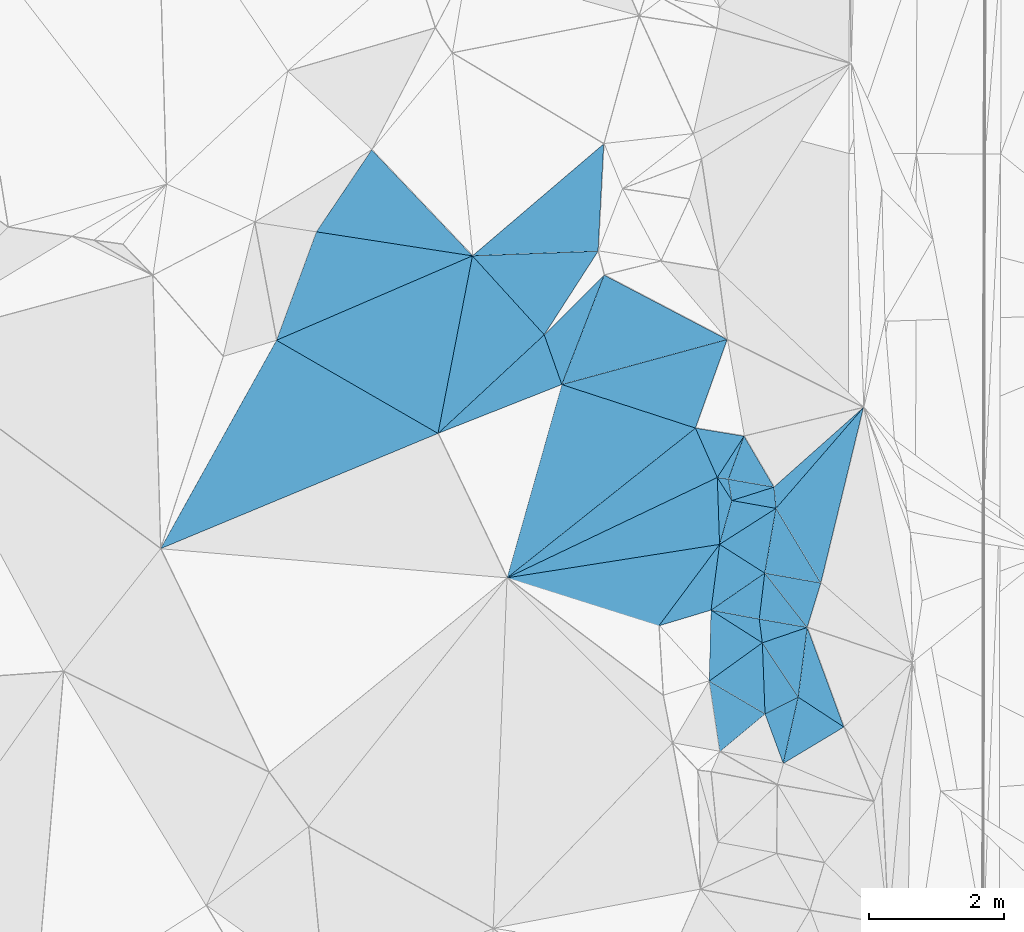
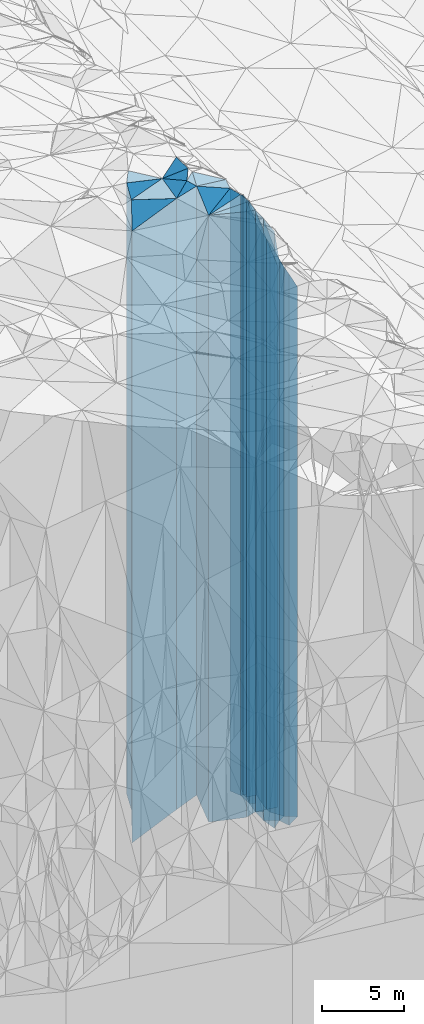
# One storey, part 249 of 275: 42 plates.
"""IFC2X3 building model written with IfcOpenShell, lengths in millimetres."""

from ifc_helpers import new_model, si_unit, frame, origin_with_axes, place, context, subcontext, project, spatial, faceted_brep, material, type_object, element, save


model = new_model("IFC2X3")

# Units and contexts
model_context = context("Model", 3, precision=1e-05, world=origin_with_axes())
body_context = subcontext(model_context, "Body", "Model", "MODEL_VIEW")
ifc_project = project(units=[si_unit("LENGTHUNIT", "METRE", prefix="MILLI"), si_unit("AREAUNIT", "SQUARE_METRE"), si_unit("VOLUMEUNIT", "CUBIC_METRE"), si_unit("MASSUNIT", "GRAM", prefix="KILO"), si_unit("TIMEUNIT", "SECOND"), si_unit("PLANEANGLEUNIT", "RADIAN"), si_unit("SOLIDANGLEUNIT", "STERADIAN"), si_unit("THERMODYNAMICTEMPERATUREUNIT", "DEGREE_CELSIUS"), si_unit("LUMINOUSINTENSITYUNIT", "LUMEN")], contexts=[model_context])

# Site, building, storey
site_placement = place(None, origin_with_axes())
site = spatial("IfcSite", under=ifc_project, at=site_placement, CompositionType="ELEMENT")
building_placement = place(site_placement, origin_with_axes())
building = spatial("IfcBuilding", under=site, at=building_placement, Name="Undefined", CompositionType="ELEMENT")
storey_placement = place(building_placement, origin_with_axes())
storey = spatial("IfcBuildingStorey", under=building, at=storey_placement, Name="Undefined", CompositionType="ELEMENT", Elevation=0.0)

# Plates
ifc_material = material()
plate_type_1 = type_object("IfcPlateType", PredefinedType="NOTDEFINED")
plate_1_placement = place(storey_placement, frame((-100152.82634146, 92751.0020205574, 28714.0), z_axis=(0.58413574837541, -0.811655978521627, 0.0), x_axis=(-0.811655978521627, -0.584135748375411, 0.0)))
element("IfcPlate", 1, at=plate_1_placement, inside=storey, type_object=plate_type_1, material=ifc_material, Name="00", context=body_context, shape_type="Brep", body=[
    faceted_brep([(0.0, -21496.0, 1.45519152283669e-11), (583.524658203136, -20886.0, 878.634704589844), (583.524658203136, 20886.0, 878.634704589844), (1.09139364212751e-11, 20886.0, 0.0), (970.82440185548, -23986.0, -7.39237293601036e-09), (970.82440185548, 20886.0, -7.39237293601036e-09)], [[[0, 1, 2, 3]], [[1, 4, 5, 2]], [[4, 0, 3, 5]], [[5, 3, 2]], [[4, 1, 0]]]),
])
plate_type_2 = type_object("IfcPlateType", PredefinedType="NOTDEFINED")
plate_2_placement = place(storey_placement, frame((-99622.3164634712, 91946.8507478749, 28294.0), z_axis=(0.453608377104646, -0.891201122205583, 0.0), x_axis=(-0.891201122205591, -0.453608377104629, 0.0)))
element("IfcPlate", 2, at=plate_2_placement, inside=storey, type_object=plate_type_2, material=ifc_material, Name="00", context=body_context, shape_type="Brep", body=[
    faceted_brep([(2.18278728425503e-11, -20466.0, 0.0), (643.225646972678, -20636.0, 776.119018554688), (643.225646972678, 20466.0, 776.119018554688), (2.18278728425503e-11, 20466.0, 0.0), (550.817565917969, -21306.0, 4.33647073805332e-09), (550.817565917969, 20466.0, 4.33647073805332e-09)], [[[0, 1, 2, 3]], [[1, 4, 5, 2]], [[4, 0, 3, 5]], [[5, 3, 2]], [[4, 1, 0]]]),
])
plate_type_3 = type_object("IfcPlateType", PredefinedType="NOTDEFINED")
plate_3_placement = place(storey_placement, frame((-99488.353856279, 92979.2043790858, 27584.0), z_axis=(0.991685476762289, -0.128685333969147, 0.0), x_axis=(-0.12868533396916, -0.991685476762288, 0.0)))
element("IfcPlate", 3, at=plate_3_placement, inside=storey, type_object=plate_type_3, material=ifc_material, Name="00", context=body_context, shape_type="Brep", body=[
    faceted_brep([(-1.45519152283669e-11, -20596.0, -1.45519152283669e-11), (1394.12805175781, -19756.0, 728.908142089844), (1394.12805175781, 19756.0, 728.908142089844), (-1.45519152283669e-11, 19756.0, -1.45519152283669e-11), (1041.00915527341, -21176.0, -5.67524693906307e-09), (1041.00915527341, 19756.0, -5.67524693906307e-09)], [[[0, 1, 2, 3]], [[1, 4, 5, 2]], [[4, 0, 3, 5]], [[5, 3, 2]], [[4, 1, 0]]]),
])
plate_type_4 = type_object("IfcPlateType", PredefinedType="NOTDEFINED")
plate_4_placement = place(storey_placement, frame((-100113.205703667, 91696.9952819352, 28294.0), z_axis=(-0.453608377104638, 0.891201122205586, 0.0), x_axis=(0.891201122205586, 0.453608377104638, 0.0)))
element("IfcPlate", 4, at=plate_4_placement, inside=storey, type_object=plate_type_4, material=ifc_material, Name="00", context=body_context, shape_type="Brep", body=[
    faceted_brep([(1.45519152283669e-11, -21306.0, 3.63797880709171e-12), (442.796325683594, -21916.0, 957.304260253892), (442.796325683594, 20466.0, 957.304260253892), (2.18278728425503e-11, 20466.0, 0.0), (550.817565917961, -20466.0, 4.33647073805332e-09), (550.817565917969, 20466.0, 4.33647073805332e-09)], [[[0, 1, 2, 3]], [[1, 4, 5, 2]], [[4, 0, 3, 5]], [[5, 3, 2]], [[4, 1, 0]]]),
])
plate_type_5 = type_object("IfcPlateType", PredefinedType="NOTDEFINED")
plate_5_placement = place(storey_placement, frame((-99843.5058046451, 90963.4000498981, 27584.0), z_axis=(-0.514713642050979, 0.85736215608494, 0.0), x_axis=(0.857362156084938, 0.514713642050983, 0.0)))
element("IfcPlate", 5, at=plate_5_placement, inside=storey, type_object=plate_type_5, material=ifc_material, Name="00", context=body_context, shape_type="Brep", body=[
    faceted_brep([(-7.27595761418343e-12, -21346.0, -1.45519152283669e-11), (695.834838867173, -21176.0, 729.324218750015), (695.834838867173, 19756.0, 729.324218750015), (-1.45519152283669e-11, 19756.0, -1.45519152283669e-11), (1048.09350585937, -19756.0, -1.01863406598568e-08), (1048.09350585937, 19756.0, -1.01863406598568e-08)], [[[0, 1, 2, 3]], [[1, 4, 5, 2]], [[4, 0, 3, 5]], [[5, 3, 2]], [[4, 1, 0]]]),
])
plate_type_6 = type_object("IfcPlateType", PredefinedType="NOTDEFINED")
plate_6_placement = place(storey_placement, frame((-100786.670575956, 94209.234336204, 30264.0), z_axis=(0.155487003987169, -0.98783793791851, 0.0), x_axis=(-0.98783793791851, -0.155487003987171, 0.0)))
element("IfcPlate", 6, at=plate_6_placement, inside=storey, type_object=plate_type_6, material=ifc_material, Name="00", context=body_context, shape_type="Brep", body=[
    faceted_brep([(1.45519152283669e-11, -22436.0, 0.0), (1075.52282714842, -22716.0, 1052.1173095703), (1075.52282714842, 22436.0, 1052.1173095703), (1.45519152283669e-11, 22436.0, 0.0), (3187.28735351563, -22796.0, 1.68220140039921e-08), (3187.28735351563, 22436.0, 1.68220140039921e-08)], [[[0, 1, 2, 3]], [[1, 4, 5, 2]], [[4, 0, 3, 5]], [[5, 3, 2]], [[4, 1, 0]]]),
])
plate_type_7 = type_object("IfcPlateType", PredefinedType="NOTDEFINED")
plate_7_placement = place(storey_placement, frame((-100784.40104888, 91137.8022843352, 28714.0), z_axis=(-0.640092212727741, 0.768298092673218, 0.0), x_axis=(0.768298092673218, 0.640092212727741, 0.0)))
element("IfcPlate", 7, at=plate_7_placement, inside=storey, type_object=plate_type_7, material=ifc_material, Name="00", context=body_context, shape_type="Brep", body=[
    faceted_brep([(-3.63797880709171e-12, -23616.0, 2.91038304567337e-11), (549.442260742177, -23986.0, 903.832519531279), (549.442260742177, 20886.0, 903.832519531279), (1.09139364212751e-11, 20886.0, 0.0), (873.613159179684, -20886.0, -2.4156179279089e-09), (873.613159179684, 20886.0, -2.4156179279089e-09)], [[[0, 1, 2, 3]], [[1, 4, 5, 2]], [[4, 0, 3, 5]], [[5, 3, 2]], [[4, 1, 0]]]),
])
plate_type_8 = type_object("IfcPlateType", PredefinedType="NOTDEFINED")
plate_8_placement = place(storey_placement, frame((-99488.353856279, 92979.2043790858, 28004.0), z_axis=(-0.170841814937067, -0.985298469636997, 0.0), x_axis=(-0.985298469636999, 0.170841814937059, 0.0)))
element("IfcPlate", 8, at=plate_8_placement, inside=storey, type_object=plate_type_8, material=ifc_material, Name="00", context=body_context, shape_type="Brep", body=[
    faceted_brep([(0.0, -20176.0, 0.0), (615.717224121094, -22206.0, 338.367126464844), (615.717224121094, 20176.0, 338.367126464844), (0.0, 20176.0, 0.0), (721.110229492188, -22376.0, -9.60426405072212e-10), (721.110229492188, 20176.0, -9.60426405072212e-10)], [[[0, 1, 2, 3]], [[1, 4, 5, 2]], [[4, 0, 3, 5]], [[5, 3, 2]], [[4, 1, 0]]]),
])
plate_type_9 = type_object("IfcPlateType", PredefinedType="NOTDEFINED")
plate_9_placement = place(storey_placement, frame((-100152.82634146, 92751.0020205574, 29019.0), z_axis=(-0.991527222614213, -0.129899063949456, 0.0), x_axis=(-0.129899063949469, 0.991527222614211, 0.0)))
element("IfcPlate", 9, at=plate_9_placement, inside=storey, type_object=plate_type_9, material=ifc_material, Name="00", context=body_context, shape_type="Brep", body=[
    faceted_brep([(0.0, -21191.0, 0.0), (578.440979003892, -23661.0, 691.307495117188), (578.440979003892, 21191.0, 691.307495117188), (0.0, 21191.0, 0.0), (354.400909423828, -21361.0, -5.82076609134674e-11), (354.400909423828, 21191.0, -5.82076609134674e-11)], [[[0, 1, 2, 3]], [[1, 4, 5, 2]], [[4, 0, 3, 5]], [[5, 3, 2]], [[4, 1, 0]]]),
])
plate_type_10 = type_object("IfcPlateType", PredefinedType="NOTDEFINED")
plate_10_placement = place(storey_placement, frame((-100117.352133444, 93783.5433420383, 28004.0), z_axis=(0.992915865493943, -0.118819544059107, 0.0), x_axis=(-0.118819544059102, -0.992915865493944, 0.0)))
element("IfcPlate", 10, at=plate_10_placement, inside=storey, type_object=plate_type_10, material=ifc_material, Name="00", context=body_context, shape_type="Brep", body=[
    faceted_brep([(-1.45519152283669e-11, -22386.0, 0.0), (723.903625488281, -20176.0, 720.113586425796), (723.903625488281, 20176.0, 720.113586425796), (0.0, 20176.0, 0.0), (686.0029296875, -22376.0, -2.8521753847599e-09), (686.0029296875, 20176.0, -2.8521753847599e-09)], [[[0, 1, 2, 3]], [[1, 4, 5, 2]], [[4, 0, 3, 5]], [[5, 3, 2]], [[4, 1, 0]]]),
])
plate_type_11 = type_object("IfcPlateType", PredefinedType="NOTDEFINED")
plate_11_placement = place(storey_placement, frame((-100117.352133444, 93783.5433420383, 29104.0), z_axis=(0.567587410162593, -0.823313143235866, 0.0), x_axis=(-0.823313143235862, -0.567587410162598, 0.0)))
element("IfcPlate", 11, at=plate_11_placement, inside=storey, type_object=plate_type_11, material=ifc_material, Name="00", context=body_context, shape_type="Brep", body=[
    faceted_brep([(3.63797880709171e-12, -21286.0, 0.0), (453.71701049804, -21276.0, 514.52978515625), (453.71701049804, 21276.0, 514.52978515625), (0.0, 21276.0, 0.0), (966.902282714844, -23576.0, -2.64844857156277e-09), (966.902282714844, 21276.0, -2.64844857156277e-09)], [[[0, 1, 2, 3]], [[1, 4, 5, 2]], [[4, 0, 3, 5]], [[5, 3, 2]], [[4, 1, 0]]]),
])
plate_type_12 = type_object("IfcPlateType", PredefinedType="NOTDEFINED")
plate_12_placement = place(storey_placement, frame((-101685.522203732, 93002.6831556719, 30254.0), z_axis=(-0.287833306916114, 0.957680524720919, 0.0), x_axis=(0.957680524720917, 0.287833306916119, 0.0)))
element("IfcPlate", 12, at=plate_12_placement, inside=storey, type_object=plate_type_12, material=ifc_material, Name="00", context=body_context, shape_type="Brep", body=[
    faceted_brep([(0.0, -22726.0, 0.0), (1208.09826660156, -22446.0, 896.771118164077), (1208.09826660156, 22426.0, 896.771118164077), (-1.81898940354586e-11, 22426.0, -2.91038304567337e-11), (806.225769042983, -22426.0, 4.97675500810146e-09), (806.225769042954, 22426.0, 4.94765117764473e-09)], [[[0, 1, 2, 3]], [[1, 4, 5, 2]], [[4, 0, 3, 5]], [[5, 3, 2]], [[4, 1, 0]]]),
])
plate_type_13 = type_object("IfcPlateType", PredefinedType="NOTDEFINED")
plate_13_placement = place(storey_placement, frame((-100940.801763244, 92183.9087877785, 29019.0), z_axis=(-0.58413574837541, 0.811655978521627, 0.0), x_axis=(0.811655978521632, 0.584135748375404, 0.0)))
element("IfcPlate", 13, at=plate_13_placement, inside=storey, type_object=plate_type_13, material=ifc_material, Name="00", context=body_context, shape_type="Brep", body=[
    faceted_brep([(0.0, -23681.0, 0.0), (636.057373046868, -23661.0, 836.917602539063), (636.057373046868, 21191.0, 836.917602539063), (0.0, 21191.0, 0.0), (970.824401855461, -21191.0, -7.39237293601036e-09), (970.824401855461, 21191.0, -7.39237293601036e-09)], [[[0, 1, 2, 3]], [[1, 4, 5, 2]], [[4, 0, 3, 5]], [[5, 3, 2]], [[4, 1, 0]]]),
])
plate_type_14 = type_object("IfcPlateType", PredefinedType="NOTDEFINED")
plate_14_placement = place(storey_placement, frame((-100913.415480677, 93234.7417866547, 29109.0), z_axis=(-0.567587410162593, 0.823313143235866, 0.0), x_axis=(0.823313143235862, 0.567587410162598, 0.0)))
element("IfcPlate", 14, at=plate_14_placement, inside=storey, type_object=plate_type_14, material=ifc_material, Name="00", context=body_context, shape_type="Brep", body=[
    faceted_brep([(0.0, -23571.0, 0.0), (657.460449218743, -23591.0, 730.373718261719), (657.460449218743, 21281.0, 730.373718261719), (0.0, 21281.0, 0.0), (966.902282714844, -21281.0, -2.64844857156277e-09), (966.902282714844, 21281.0, -2.64844857156277e-09)], [[[0, 1, 2, 3]], [[1, 4, 5, 2]], [[4, 0, 3, 5]], [[5, 3, 2]], [[4, 1, 0]]]),
])
plate_15_placement = place(storey_placement, frame((-99951.0378244559, 94742.7302636682, 29109.0), z_axis=(0.53811666409654, -0.842870367151208, 0.0), x_axis=(-0.842870367151209, -0.538116664096537, 0.0)))
element("IfcPlate", 15, at=plate_15_placement, inside=storey, type_object=plate_type_14, material=ifc_material, Name="00", context=body_context, shape_type="Brep", body=[
    faceted_brep([(7.27595761418343e-12, -21291.0, 2.91038304567337e-11), (656.335876464858, -21281.0, 718.973754882842), (656.335876464858, 21281.0, 718.973754882842), (0.0, 21281.0, 0.0), (991.413146972664, -23591.0, 9.60426405072212e-10), (991.413146972664, 21281.0, 9.60426405072212e-10)], [[[0, 1, 2, 3]], [[1, 4, 5, 2]], [[4, 0, 3, 5]], [[5, 3, 2]], [[4, 1, 0]]]),
])
plate_type_15 = type_object("IfcPlateType", PredefinedType="NOTDEFINED")
plate_16_placement = place(storey_placement, frame((-100117.352133444, 93783.5433420383, 28054.0), z_axis=(0.174081986064104, 0.98473116236259, 0.0), x_axis=(0.984731162362591, -0.1740819860641, 0.0)))
element("IfcPlate", 16, at=plate_16_placement, inside=storey, type_object=plate_type_15, material=ifc_material, Name="00", context=body_context, shape_type="Brep", body=[
    faceted_brep([(-1.45519152283669e-11, -22336.0, 0.0), (-3.20228147508169, -22346.0, 973.493591308594), (-3.20228147508169, 20226.0, 973.493591308594), (-1.45519152283669e-11, 20226.0, 0.0), (843.148864746094, -20226.0, 4.71482053399086e-09), (843.148864746094, 20226.0, 4.71482053399086e-09)], [[[0, 1, 2, 3]], [[1, 4, 5, 2]], [[4, 0, 3, 5]], [[5, 3, 2]], [[4, 1, 0]]]),
])
plate_type_16 = type_object("IfcPlateType", PredefinedType="NOTDEFINED")
plate_17_placement = place(storey_placement, frame((-99488.353856279, 92979.2043790858, 28004.0), z_axis=(0.324812364997839, -0.945778476993694, 0.0), x_axis=(-0.945778476993697, -0.32481236499783, 0.0)))
element("IfcPlate", 17, at=plate_17_placement, inside=storey, type_object=plate_type_16, material=ifc_material, Name="00", context=body_context, shape_type="Brep", body=[
    faceted_brep([(0.0, -20176.0, 0.0), (462.020172119148, -20756.0, 932.865112304688), (462.020172119148, 20176.0, 932.865112304688), (0.0, 20176.0, 0.0), (702.566711425781, -22206.0, -1.41153577715158e-09), (702.566711425781, 20176.0, -1.41153577715158e-09)], [[[0, 1, 2, 3]], [[1, 4, 5, 2]], [[4, 0, 3, 5]], [[5, 3, 2]], [[4, 1, 0]]]),
])
plate_type_17 = type_object("IfcPlateType", PredefinedType="NOTDEFINED")
plate_18_placement = place(storey_placement, frame((-101143.836132756, 95931.9452130013, 30289.0), z_axis=(-0.309542062965778, -0.950885750894865, 0.0), x_axis=(-0.950885750894865, 0.309542062965775, 0.0)))
element("IfcPlate", 18, at=plate_18_placement, inside=storey, type_object=plate_type_17, material=ifc_material, Name="00", context=body_context, shape_type="Brep", body=[
    faceted_brep([(1.45519152283669e-11, -22461.0, 0.0), (1967.607421875, -22771.0, 2973.38549804688), (1967.607421875, 22461.0, 2973.38549804688), (-7.27595761418343e-12, 22461.0, -2.91038304567337e-11), (2081.97021484376, -22931.0, 8.81118467077613e-09), (2081.97021484376, 22461.0, 8.81118467077613e-09)], [[[0, 1, 2, 3]], [[1, 4, 5, 2]], [[4, 0, 3, 5]], [[5, 3, 2]], [[4, 1, 0]]]),
])
plate_type_18 = type_object("IfcPlateType", PredefinedType="NOTDEFINED")
plate_19_placement = place(storey_placement, frame((-99951.0378244559, 94742.7302636682, 29114.0), z_axis=(-0.174962871011688, -0.984575032065788, 0.0), x_axis=(-0.984575032065788, 0.174962871011689, 0.0)))
element("IfcPlate", 19, at=plate_19_placement, inside=storey, type_object=plate_type_18, material=ifc_material, Name="00", context=body_context, shape_type="Brep", body=[
    faceted_brep([(3.63797880709171e-12, -21286.0, 0.0), (729.401184082031, -23586.0, 671.471496582046), (729.401184082031, 21286.0, 671.471496582046), (0.0, 21286.0, 1.45519152283669e-11), (662.87255859375, -23296.0, -1.89174897968769e-09), (662.87255859375, 21286.0, -1.89174897968769e-09)], [[[0, 1, 2, 3]], [[1, 4, 5, 2]], [[4, 0, 3, 5]], [[5, 3, 2]], [[4, 1, 0]]]),
])
plate_type_19 = type_object("IfcPlateType", PredefinedType="NOTDEFINED")
plate_20_placement = place(storey_placement, frame((-99488.353856279, 92979.2043790858, 28004.0), z_axis=(-0.956207195936515, 0.292690618980567, 0.0), x_axis=(0.292690618980565, 0.956207195936516, 0.0)))
element("IfcPlate", 20, at=plate_20_placement, inside=storey, type_object=plate_type_19, material=ifc_material, Name="00", context=body_context, shape_type="Brep", body=[
    faceted_brep([(0.0, -20176.0, 0.0), (585.01281738282, -22386.0, 836.875122070327), (585.01281738282, 20176.0, 836.875122070327), (0.0, 20176.0, 0.0), (687.677246093743, -20276.0, -1.97906047105789e-09), (687.677246093743, 20176.0, -1.97906047105789e-09)], [[[0, 1, 2, 3]], [[1, 4, 5, 2]], [[4, 0, 3, 5]], [[5, 3, 2]], [[4, 1, 0]]]),
])
plate_type_20 = type_object("IfcPlateType", PredefinedType="NOTDEFINED")
plate_21_placement = place(storey_placement, frame((-98655.348942853, 96236.2748134191, 25960.0), z_axis=(0.66450984016583, -0.747279514186481, 0.0), x_axis=(-0.747279514186484, -0.664509840165827, 0.0)))
element("IfcPlate", 21, at=plate_21_placement, inside=storey, type_object=plate_type_20, material=ifc_material, Name="00", context=body_context, shape_type="Brep", body=[
    faceted_brep([(-9.09494701772928e-12, -18132.0, 0.0), (1960.71679687501, -24440.0, 255.097229003906), (1960.71679687501, 18132.0, 255.097229003906), (-9.09494701772928e-12, 18132.0, 0.0), (1773.83337402343, -24530.0, 4.59840521216393e-09), (1773.83337402343, 18132.0, 4.59840521216393e-09)], [[[0, 1, 2, 3]], [[1, 4, 5, 2]], [[4, 0, 3, 5]], [[5, 3, 2]], [[4, 1, 0]]]),
])
plate_type_21 = type_object("IfcPlateType", PredefinedType="NOTDEFINED")
plate_22_placement = place(storey_placement, frame((-100603.685573631, 94858.7083456334, 29114.0), z_axis=(0.174962871011688, 0.984575032065788, 0.0), x_axis=(0.984575032065788, -0.174962871011689, 0.0)))
element("IfcPlate", 22, at=plate_22_placement, inside=storey, type_object=plate_type_21, material=ifc_material, Name="00", context=body_context, shape_type="Brep", body=[
    faceted_brep([(0.0, -23296.0, 0.0), (578.391723632798, -21376.0, 304.734313964829), (578.391723632798, 21286.0, 304.734313964829), (0.0, 21286.0, 1.45519152283669e-11), (662.872558593735, -21286.0, -1.92085281014442e-09), (662.87255859375, 21286.0, -1.89174897968769e-09)], [[[0, 1, 2, 3]], [[1, 4, 5, 2]], [[4, 0, 3, 5]], [[5, 3, 2]], [[4, 1, 0]]]),
])
plate_type_22 = type_object("IfcPlateType", PredefinedType="NOTDEFINED")
plate_23_placement = place(storey_placement, frame((-100424.181463221, 95812.7933912902, 29159.0), z_axis=(0.939971611030336, -0.341252649011015, 0.0), x_axis=(-0.341252649011023, -0.939971611030333, 0.0)))
element("IfcPlate", 23, at=plate_23_placement, inside=storey, type_object=plate_type_22, material=ifc_material, Name="00", context=body_context, shape_type="Brep", body=[
    faceted_brep([(1.04591890703887e-11, -22891.0, 0.0), (558.64044189456, -21331.0, 674.404052734375), (558.64044189456, 21331.0, 674.404052734375), (2.18278728425503e-11, 21331.0, 0.0), (678.969787597664, -23361.0, -4.36557456851006e-11), (678.969787597664, 21331.0, -4.36557456851006e-11)], [[[0, 1, 2, 3]], [[1, 4, 5, 2]], [[4, 0, 3, 5]], [[5, 3, 2]], [[4, 1, 0]]]),
])
plate_type_23 = type_object("IfcPlateType", PredefinedType="NOTDEFINED")
plate_24_placement = place(storey_placement, frame((-98655.348942853, 96236.2748134191, 25960.0), z_axis=(0.755367692100909, -0.65530119008754, 0.0), x_axis=(-0.655301190087544, -0.755367692100906, 0.0)))
element("IfcPlate", 24, at=plate_24_placement, inside=storey, type_object=plate_type_23, material=ifc_material, Name="00", context=body_context, shape_type="Brep", body=[
    faceted_brep([(-9.09494701772928e-12, -18132.0, 0.0), (2377.55688476562, -22320.0, 1226.27392578125), (2377.55688476562, 18132.0, 1226.27392578125), (-9.09494701772928e-12, 18132.0, 0.0), (1977.24182128905, -24440.0, -7.97444954514503e-09), (1977.24182128905, 18132.0, -7.97444954514503e-09)], [[[0, 1, 2, 3]], [[1, 4, 5, 2]], [[4, 0, 3, 5]], [[5, 3, 2]], [[4, 1, 0]]]),
])
plate_type_24 = type_object("IfcPlateType", PredefinedType="NOTDEFINED")
plate_25_placement = place(storey_placement, frame((-100424.181463221, 95812.7933912902, 29939.0), z_axis=(0.839692537724146, -0.543062097821587, 0.0), x_axis=(-0.543062097821584, -0.839692537724149, 0.0)))
element("IfcPlate", 25, at=plate_25_placement, inside=storey, type_object=plate_type_24, material=ifc_material, Name="00", context=body_context, shape_type="Brep", body=[
    faceted_brep([(-3.63797880709171e-12, -22111.0, -2.91038304567337e-11), (661.729736328107, -22581.0, 152.031967163057), (661.729736328107, 22111.0, 152.031967163057), (-3.63797880709171e-12, 22111.0, -2.91038304567337e-11), (729.451843261722, -22681.0, -2.18278728425503e-09), (729.451843261722, 22111.0, -2.18278728425503e-09)], [[[0, 1, 2, 3]], [[1, 4, 5, 2]], [[4, 0, 3, 5]], [[5, 3, 2]], [[4, 1, 0]]]),
])
plate_type_25 = type_object("IfcPlateType", PredefinedType="NOTDEFINED")
plate_26_placement = place(storey_placement, frame((-99980.8983192143, 95057.5450518418, 29159.0), z_axis=(-0.170841814937067, -0.985298469636997, 0.0), x_axis=(-0.985298469636999, 0.170841814937059, 0.0)))
element("IfcPlate", 26, at=plate_26_placement, inside=storey, type_object=plate_type_25, material=ifc_material, Name="00", context=body_context, shape_type="Brep", body=[
    faceted_brep([(0.0, -21331.0, -1.45519152283669e-11), (579.661682128906, -23251.0, 302.311614990234), (579.661682128906, 21331.0, 302.311614990234), (2.18278728425503e-11, 21331.0, 0.0), (685.054748535156, -23361.0, -9.16770659387112e-10), (685.054748535156, 21331.0, -9.16770659387112e-10)], [[[0, 1, 2, 3]], [[1, 4, 5, 2]], [[4, 0, 3, 5]], [[5, 3, 2]], [[4, 1, 0]]]),
])
plate_type_26 = type_object("IfcPlateType", PredefinedType="NOTDEFINED")
plate_27_placement = place(storey_placement, frame((-100655.881708509, 95174.5810470556, 30119.0), z_axis=(-0.154398731049965, -0.988008619319771, 0.0), x_axis=(-0.988008619319777, 0.15439873104993, 0.0)))
element("IfcPlate", 27, at=plate_27_placement, inside=storey, type_object=plate_type_26, material=ifc_material, Name="00", context=body_context, shape_type="Brep", body=[
    faceted_brep([(1.45519152283669e-11, -22401.0, 0.0), (-100.34057617186, -22291.0, 304.025939941406), (-100.34057617186, 22291.0, 304.025939941406), (1.45519152283669e-11, 22291.0, 0.0), (166.433166503921, -22501.0, 2.91038304567337e-10), (166.433166503921, 22291.0, 2.91038304567337e-10)], [[[0, 1, 2, 3]], [[1, 4, 5, 2]], [[4, 0, 3, 5]], [[5, 3, 2]], [[4, 1, 0]]]),
])
plate_type_27 = type_object("IfcPlateType", PredefinedType="NOTDEFINED")
plate_28_placement = place(storey_placement, frame((-100424.181463221, 95812.7933912902, 29939.0), z_axis=(-0.163344327026642, -0.986569121160912, 0.0), x_axis=(-0.986569121160911, 0.163344327026645, 0.0)))
element("IfcPlate", 28, at=plate_28_placement, inside=storey, type_object=plate_type_27, material=ifc_material, Name="00", context=body_context, shape_type="Brep", body=[
    faceted_brep([(-3.63797880709171e-12, -22111.0, -2.91038304567337e-11), (290.766265869155, -22681.0, 668.995483398423), (290.766265869155, 22111.0, 668.995483398423), (-3.63797880709171e-12, 22111.0, -2.91038304567337e-11), (729.451843261748, -22811.0, -3.49245965480804e-10), (729.451843261722, 22111.0, -2.18278728425503e-09)], [[[0, 1, 2, 3]], [[1, 4, 5, 2]], [[4, 0, 3, 5]], [[5, 3, 2]], [[4, 1, 0]]]),
])
plate_type_28 = type_object("IfcPlateType", PredefinedType="NOTDEFINED")
plate_29_placement = place(storey_placement, frame((-109067.971722506, 94144.8035971109, 30554.0), z_axis=(-0.383746944880569, 0.923438293712596, 0.0), x_axis=(0.923438293712597, 0.383746944880565, 0.0)))
element("IfcPlate", 29, at=plate_29_placement, inside=storey, type_object=plate_type_28, material=ifc_material, Name="00", context=body_context, shape_type="Brep", body=[
    faceted_brep([(2.91038304567337e-11, -22886.0, 0.0), (2771.43505859375, -22726.0, 2192.81713867188), (2771.43505859375, 22726.0, 2192.81713867188), (-7.27595761418343e-12, 22726.0, 0.0), (4451.12353515624, -22826.0, 3.10828909277916e-08), (4451.12353515624, 22726.0, 3.10828909277916e-08)], [[[0, 1, 2, 3]], [[1, 4, 5, 2]], [[4, 0, 3, 5]], [[5, 3, 2]], [[4, 1, 0]]]),
])
plate_type_29 = type_object("IfcPlateType", PredefinedType="NOTDEFINED")
plate_30_placement = place(storey_placement, frame((-104447.99235347, 98483.7194328559, 30459.0), z_axis=(0.395695682953438, -0.91838168889194, 0.0), x_axis=(-0.91838168889194, -0.395695682953439, 0.0)))
element("IfcPlate", 30, at=plate_30_placement, inside=storey, type_object=plate_type_29, material=ifc_material, Name="00", context=body_context, shape_type="Brep", body=[
    faceted_brep([(0.0, -22631.0, 2.91038304567337e-11), (1509.04589843751, -22921.0, 2214.42553710938), (1509.04589843751, 22631.0, 2214.42553710938), (2.18278728425503e-11, 22631.0, 0.0), (3160.14233398439, -22821.0, -1.13504938781261e-08), (3160.14233398439, 22631.0, -1.13504938781261e-08)], [[[0, 1, 2, 3]], [[1, 4, 5, 2]], [[4, 0, 3, 5]], [[5, 3, 2]], [[4, 1, 0]]]),
])
plate_type_30 = type_object("IfcPlateType", PredefinedType="NOTDEFINED")
plate_31_placement = place(storey_placement, frame((-100674.275852957, 97243.8953430122, 30139.0), z_axis=(0.262937152069057, -0.964812963253404, 0.0), x_axis=(-0.964812963253403, -0.262937152069061, 0.0)))
element("IfcPlate", 31, at=plate_31_placement, inside=storey, type_object=plate_type_30, material=ifc_material, Name="00", context=body_context, shape_type="Brep", body=[
    faceted_brep([(-1.45519152283669e-11, -22311.0, 1.45519152283669e-11), (797.998291015596, -22611.0, 1142.32165527347), (797.998291015596, 22311.0, 1142.32165527347), (-1.45519152283669e-11, 22311.0, 1.45519152283669e-11), (2538.60205078124, -23081.0, 1.56578607857227e-08), (2538.60205078124, 22311.0, 1.56578607857227e-08)], [[[0, 1, 2, 3]], [[1, 4, 5, 2]], [[4, 0, 3, 5]], [[5, 3, 2]], [[4, 1, 0]]]),
])
plate_type_31 = type_object("IfcPlateType", PredefinedType="NOTDEFINED")
plate_32_placement = place(storey_placement, frame((-100786.670575956, 94209.234336204, 30119.0), z_axis=(-0.962527066959694, 0.271185628988647, 0.0), x_axis=(0.271185628988662, 0.96252706695969, 0.0)))
element("IfcPlate", 32, at=plate_32_placement, inside=storey, type_object=plate_type_31, material=ifc_material, Name="00", context=body_context, shape_type="Brep", body=[
    faceted_brep([(0.0, -22581.0, 0.0), (944.781494140625, -22501.0, 301.144470214844), (944.781494140625, 22291.0, 301.144470214844), (1.45519152283669e-11, 22291.0, 0.0), (674.759216308594, -22291.0, -4.80213202536106e-09), (674.759216308594, 22291.0, -4.80213202536106e-09)], [[[0, 1, 2, 3]], [[1, 4, 5, 2]], [[4, 0, 3, 5]], [[5, 3, 2]], [[4, 1, 0]]]),
])
plate_type_32 = type_object("IfcPlateType", PredefinedType="NOTDEFINED")
plate_33_placement = place(storey_placement, frame((-102496.021204896, 98198.748144595, 30459.0), z_axis=(0.705757959680974, -0.708453034679751, 0.0), x_axis=(-0.708453034679754, -0.705757959680972, 0.0)))
element("IfcPlate", 33, at=plate_33_placement, inside=storey, type_object=plate_type_32, material=ifc_material, Name="00", context=body_context, shape_type="Brep", body=[
    faceted_brep([(0.0, -22631.0, 2.91038304567337e-11), (1589.55932617188, -22761.0, 706.470825195283), (1589.55932617188, 22631.0, 706.470825195283), (2.18278728425503e-11, 22631.0, 0.0), (1253.55493164063, -22811.0, 6.57746568322182e-09), (1253.55493164063, 22631.0, 6.57746568322182e-09)], [[[0, 1, 2, 3]], [[1, 4, 5, 2]], [[4, 0, 3, 5]], [[5, 3, 2]], [[4, 1, 0]]]),
])
plate_type_33 = type_object("IfcPlateType", PredefinedType="NOTDEFINED")
plate_34_placement = place(storey_placement, frame((-103935.193838232, 93713.6525902667, 30224.0), z_axis=(-0.430725049100535, 0.902483203210642, 0.0), x_axis=(0.902483203210644, 0.430725049100532, 0.0)))
element("IfcPlate", 34, at=plate_34_placement, inside=storey, type_object=plate_type_33, material=ifc_material, Name="00", context=body_context, shape_type="Brep", body=[
    faceted_brep([(-7.27595761418343e-12, -22836.0, 1.45519152283669e-11), (3474.62768554687, -22526.0, 799.664123535171), (3474.62768554687, 22396.0, 799.664123535171), (0.0, 22396.0, 0.0), (3451.44897460936, -22396.0, -8.01810529083014e-09), (3451.44897460936, 22396.0, -8.01810529083014e-09)], [[[0, 1, 2, 3]], [[1, 4, 5, 2]], [[4, 0, 3, 5]], [[5, 3, 2]], [[4, 1, 0]]]),
])
plate_type_34 = type_object("IfcPlateType", PredefinedType="NOTDEFINED")
plate_35_placement = place(storey_placement, frame((-103935.193838232, 93713.6525902667, 30224.0), z_axis=(-0.155487003987169, 0.98783793791851, 0.0), x_axis=(0.987837937918509, 0.155487003987175, 0.0)))
element("IfcPlate", 35, at=plate_35_placement, inside=storey, type_object=plate_type_34, material=ifc_material, Name="00", context=body_context, shape_type="Brep", body=[
    faceted_brep([(-7.27595761418343e-12, -22836.0, 1.45519152283669e-11), (3308.14233398436, -22396.0, 984.222534179688), (3308.14233398436, 22396.0, 984.222534179688), (0.0, 22396.0, 0.0), (3187.2873535156, -22476.0, 1.68365659192204e-08), (3187.2873535156, 22396.0, 1.68365659192204e-08)], [[[0, 1, 2, 3]], [[1, 4, 5, 2]], [[4, 0, 3, 5]], [[5, 3, 2]], [[4, 1, 0]]]),
])
plate_type_35 = type_object("IfcPlateType", PredefinedType="NOTDEFINED")
plate_36_placement = place(storey_placement, frame((-104447.99235347, 98483.7194328559, 30459.0), z_axis=(-0.152113617006081, -0.988363014039542, 0.0), x_axis=(-0.988363014039542, 0.152113617006082, 0.0)))
element("IfcPlate", 36, at=plate_36_placement, inside=storey, type_object=plate_type_35, material=ifc_material, Name="00", context=body_context, shape_type="Brep", body=[
    faceted_brep([(0.0, -22631.0, 2.91038304567337e-11), (2678.23266601563, -22821.0, 1677.36987304688), (2678.23266601563, 22631.0, 1677.36987304688), (2.18278728425503e-11, 22631.0, 0.0), (2338.48242187499, -22901.0, -1.47410901263356e-08), (2338.48242187499, 22631.0, -1.47410901263356e-08)], [[[0, 1, 2, 3]], [[1, 4, 5, 2]], [[4, 0, 3, 5]], [[5, 3, 2]], [[4, 1, 0]]]),
])
plate_type_36 = type_object("IfcPlateType", PredefinedType="NOTDEFINED")
plate_37_placement = place(storey_placement, frame((-104957.633874819, 95852.908622532, 30459.0), z_axis=(-0.680451130627551, 0.732793462598902, 0.0), x_axis=(0.732793462598901, 0.680451130627552, 0.0)))
element("IfcPlate", 37, at=plate_37_placement, inside=storey, type_object=plate_type_36, material=ifc_material, Name="00", context=body_context, shape_type="Brep", body=[
    faceted_brep([(-1.45519152283669e-11, -22921.0, -5.82076609134674e-11), (2163.60009765627, -22631.0, 1581.05480957031), (2163.60009765627, 22631.0, 1581.05480957031), (2.18278728425503e-11, 22631.0, 0.0), (2147.3005371094, -22811.0, -1.13504938781261e-09), (2147.3005371094, 22631.0, -1.13504938781261e-09)], [[[0, 1, 2, 3]], [[1, 4, 5, 2]], [[4, 0, 3, 5]], [[5, 3, 2]], [[4, 1, 0]]]),
])
plate_type_37 = type_object("IfcPlateType", PredefinedType="NOTDEFINED")
plate_38_placement = place(storey_placement, frame((-106759.261880187, 98839.4344520322, 30459.0), z_axis=(0.152113617006081, 0.988363014039542, 0.0), x_axis=(0.988363014039541, -0.152113617006084, 0.0)))
element("IfcPlate", 38, at=plate_38_placement, inside=storey, type_object=plate_type_37, material=ifc_material, Name="00", context=body_context, shape_type="Brep", body=[
    faceted_brep([(0.0, -22901.0, -1.45519152283669e-11), (624.336547851577, -22781.0, 1325.21838378905), (624.336547851577, 22631.0, 1325.21838378905), (2.18278728425503e-11, 22631.0, 0.0), (2338.482421875, -22631.0, -1.47265382111073e-08), (2338.48242187499, 22631.0, -1.47410901263356e-08)], [[[0, 1, 2, 3]], [[1, 4, 5, 2]], [[4, 0, 3, 5]], [[5, 3, 2]], [[4, 1, 0]]]),
])
plate_type_38 = type_object("IfcPlateType", PredefinedType="NOTDEFINED")
plate_39_placement = place(storey_placement, frame((-103123.551949591, 96576.4025696753, 30139.0), z_axis=(-0.262937152069057, 0.964812963253404, 0.0), x_axis=(0.964812963253403, 0.262937152069059, 0.0)))
element("IfcPlate", 39, at=plate_39_placement, inside=storey, type_object=plate_type_38, material=ifc_material, Name="00", context=body_context, shape_type="Brep", body=[
    faceted_brep([(0.0, -23081.0, 0.0), (1032.02478027342, -22951.0, 1400.25891113283), (1032.02478027342, 22311.0, 1400.25891113283), (-1.45519152283669e-11, 22311.0, 1.45519152283669e-11), (2538.60205078124, -22311.0, 1.56142050400376e-08), (2538.60205078124, 22311.0, 1.56578607857227e-08)], [[[0, 1, 2, 3]], [[1, 4, 5, 2]], [[4, 0, 3, 5]], [[5, 3, 2]], [[4, 1, 0]]]),
])
plate_type_39 = type_object("IfcPlateType", PredefinedType="NOTDEFINED")
plate_40_placement = place(storey_placement, frame((-102586.728830791, 98552.2621140564, 30459.0), z_axis=(0.0368009419966679, -0.999322615909476, 0.0), x_axis=(-0.999322615909476, -0.0368009419966659, 0.0)))
element("IfcPlate", 40, at=plate_40_placement, inside=storey, type_object=plate_type_39, material=ifc_material, Name="00", context=body_context, shape_type="Brep", body=[
    faceted_brep([(1.45519152283669e-11, -22701.0, 0.0), (842.404724121108, -22811.0, 1208.03735351564), (842.404724121108, 22631.0, 1208.03735351564), (2.18278728425503e-11, 22631.0, 0.0), (1862.5251464844, -22631.0, 8.62928573042154e-09), (1862.5251464844, 22631.0, 8.62928573042154e-09)], [[[0, 1, 2, 3]], [[1, 4, 5, 2]], [[4, 0, 3, 5]], [[5, 3, 2]], [[4, 1, 0]]]),
])
plate_type_40 = type_object("IfcPlateType", PredefinedType="NOTDEFINED")
plate_41_placement = place(storey_placement, frame((-104447.99235347, 98483.7194328559, 30414.0), z_axis=(-0.0368009419966679, 0.999322615909476, 0.0), x_axis=(0.999322615909476, 0.0368009419966659, 0.0)))
element("IfcPlate", 41, at=plate_41_placement, inside=storey, type_object=plate_type_40, material=ifc_material, Name="00", context=body_context, shape_type="Brep", body=[
    faceted_brep([(1.45519152283669e-11, -22676.0, 2.91038304567337e-11), (2005.23461914063, -22586.0, 1585.69665527342), (2005.23461914063, 22586.0, 1585.69665527342), (-1.45519152283669e-11, 22586.0, 0.0), (1862.52514648436, -22746.0, 8.62928573042154e-09), (1862.52514648436, 22586.0, 8.62928573042154e-09)], [[[0, 1, 2, 3]], [[1, 4, 5, 2]], [[4, 0, 3, 5]], [[5, 3, 2]], [[4, 1, 0]]]),
])
plate_type_41 = type_object("IfcPlateType", PredefinedType="NOTDEFINED")
plate_42_placement = place(storey_placement, frame((-104957.633874819, 95852.908622532, 30524.0), z_axis=(-0.366953363810185, 0.930239339518809, 0.0), x_axis=(0.93023933951881, 0.366953363810182, 0.0)))
element("IfcPlate", 42, at=plate_42_placement, inside=storey, type_object=plate_type_41, material=ifc_material, Name="00", context=body_context, shape_type="Brep", body=[
    faceted_brep([(-2.91038304567337e-11, -22856.0, 0.0), (1999.92529296873, -22746.0, 781.792175292983), (1999.92529296873, 22696.0, 781.792175292983), (-5.45696821063757e-12, 22696.0, 0.0), (1971.62365722655, -22696.0, -1.47992977872491e-08), (1971.62365722655, 22696.0, -1.47992977872491e-08)], [[[0, 1, 2, 3]], [[1, 4, 5, 2]], [[4, 0, 3, 5]], [[5, 3, 2]], [[4, 1, 0]]]),
])

save(model, "model.ifc")
